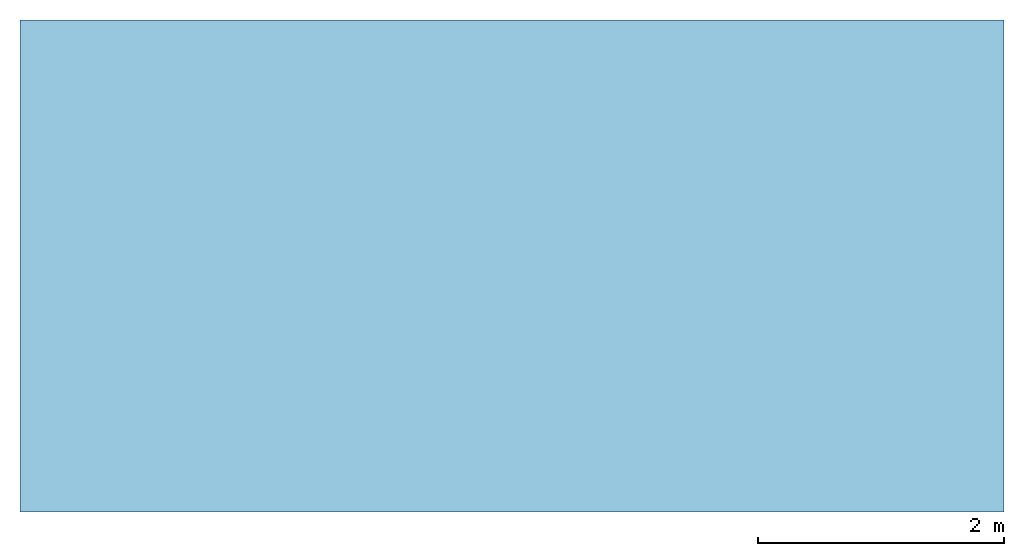
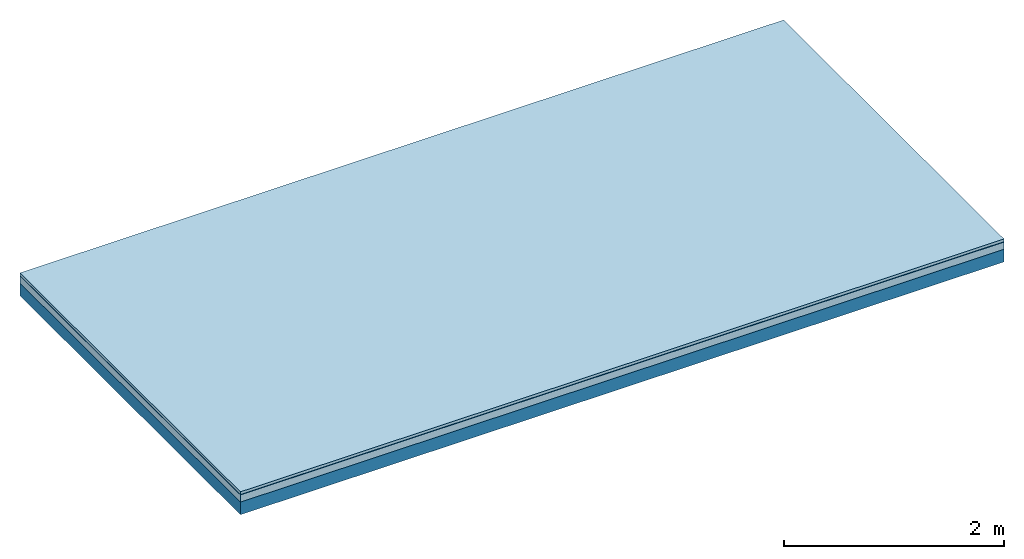
# One storey: 3 plates, 1 member, 1 element without a shape of its own.
"""IFC4 building model written with IfcOpenShell, lengths in metres."""

import ifcopenshell
import ifcopenshell.guid

model = None  # the IFC model being written
_history = None  # IfcOwnerHistory: only IFC2X3 demands one
_inside = {}  # id of a spatial element -> (the spatial element, [elements in it])
_under = {}  # id of a project, library or spatial element -> (it, [spatial elements below it])
_declared = {}  # id of a project -> (the project, [libraries it declares])
_typed = {}  # id of a type object -> (the type object, [elements of that type])
_made_of = {}  # id of a material, layer set ... -> (it, [elements and type objects made of it])


def new_model(schema):
    """Start an empty IFC model of exactly this schema.

    Asked for "IFC4X3", IfcOpenShell would pick the latest addendum, in which some entities
    have other attributes; the version numbers below select the first issue.
    IFC2X3 requires an IfcOwnerHistory on every rooted entity: one is made here for all.
    """
    global model, _history
    if schema == "IFC4X3":
        model = ifcopenshell.file(schema_version=(4, 3, 0, 0))
    else:
        model = ifcopenshell.file(schema=schema)
    _inside.clear()
    _under.clear()
    _declared.clear()
    _typed.clear()
    _made_of.clear()
    _history = None
    if model.schema == "IFC2X3":
        org = make("IfcOrganization", Name="unknown")
        user = make(
            "IfcPersonAndOrganization",
            ThePerson=make("IfcPerson", FamilyName="unknown"),
            TheOrganization=org,
        )
        app = make(
            "IfcApplication",
            ApplicationDeveloper=org,
            Version="unknown",
            ApplicationFullName="unknown",
            ApplicationIdentifier="unknown",
        )
        _history = make(
            "IfcOwnerHistory",
            OwningUser=user,
            OwningApplication=app,
            ChangeAction="ADDED",
            CreationDate=0,
        )
    return model


def make(cls, **values):
    """One entity of the class cls with the attributes given. An attribute that is None is left unset."""
    return model.create_entity(
        cls, **{name: value for name, value in values.items() if value is not None}
    )


def rooted(cls, **values):
    """An entity with a GlobalId (a new one), such as an element, a storey or a relation."""
    return make(cls, GlobalId=ifcopenshell.guid.new(), OwnerHistory=_history, **values)


def si_unit(unit_type, name, prefix=None):
    """IfcSIUnit, for example si_unit("LENGTHUNIT", "METRE", prefix="MILLI")."""
    return make("IfcSIUnit", UnitType=unit_type, Prefix=prefix, Name=name)


def derived_unit(unit_type, elements):
    """IfcDerivedUnit: a product of units, each with its exponent."""
    return make(
        "IfcDerivedUnit",
        Elements=[
            make("IfcDerivedUnitElement", Unit=unit, Exponent=power)
            for unit, power in elements
        ],
        UnitType=unit_type,
    )


def assignment(units):
    """IfcUnitAssignment: the units of a project."""
    return None if units is None else make("IfcUnitAssignment", Units=units)


def point(xyz):
    """IfcCartesianPoint."""
    return None if xyz is None else make("IfcCartesianPoint", Coordinates=xyz)


def direction(xyz):
    """IfcDirection."""
    return None if xyz is None else make("IfcDirection", DirectionRatios=xyz)


def frame(location, z_axis=None, x_axis=None):
    """IfcAxis2Placement3D, a coordinate frame: its origin and axes. An axis left out is left unset."""
    return make(
        "IfcAxis2Placement3D",
        Location=point(location),
        Axis=direction(z_axis),
        RefDirection=direction(x_axis),
    )


def frame_2d(location, x_axis=None):
    """IfcAxis2Placement2D, a coordinate frame in the plane: its origin and x axis."""
    return make(
        "IfcAxis2Placement2D", Location=point(location), RefDirection=direction(x_axis)
    )


def origin():
    """The frame at (0, 0, 0) with its axes left unset."""
    return frame((0.0, 0.0, 0.0))


def origin_with_axes():
    """The frame at (0, 0, 0) with the z axis (0, 0, 1) and the x axis (1, 0, 0) written out."""
    return frame((0.0, 0.0, 0.0), z_axis=(0.0, 0.0, 1.0), x_axis=(1.0, 0.0, 0.0))


def place(relative_to, where):
    """IfcLocalPlacement: puts the frame where relative to a parent placement (None: the world)."""
    return make(
        "IfcLocalPlacement", PlacementRelTo=relative_to, RelativePlacement=where
    )


def context(
    kind, dimensions, precision=None, world=None, true_north=None, identifier=None
):
    """IfcGeometricRepresentationContext, for example the 3D "Model" context."""
    return make(
        "IfcGeometricRepresentationContext",
        ContextIdentifier=identifier,
        ContextType=kind,
        CoordinateSpaceDimension=dimensions,
        Precision=precision,
        WorldCoordinateSystem=world,
        TrueNorth=true_north,
    )


def project(units=None, contexts=None):
    """IfcProject with its units and contexts."""
    return rooted(
        "IfcProject",
        Name="project",
        RepresentationContexts=contexts,
        UnitsInContext=assignment(units),
    )


def spatial(cls, under=None, at=None, **own):
    """A site, building, storey or space (cls), placed at a placement, below another one or the project."""
    s = rooted(cls, ObjectPlacement=at, **own)
    if under is not None:
        _under.setdefault(under.id(), (under, []))[1].append(s)
    return s


def profile(cls, at=None, kind="AREA", **sizes):
    """A parametric profile (cls). Its sizes go by their IFC names, for example OverallWidth=200.0."""
    return make(cls, ProfileType=kind, Position=at, **sizes)


def rectangle(**sizes):
    """IfcRectangleProfileDef."""
    return profile("IfcRectangleProfileDef", **sizes)


def extrude(swept, where, along, depth):
    """IfcExtrudedAreaSolid: the profile swept, set in the frame where, extruded along a direction by depth."""
    return make(
        "IfcExtrudedAreaSolid",
        SweptArea=swept,
        Position=where,
        ExtrudedDirection=direction(along),
        Depth=depth,
    )


def shape(context_of_items, identifier, shape_type, items):
    """IfcShapeRepresentation: the items that make up one representation, for example the "Body"."""
    return make(
        "IfcShapeRepresentation",
        ContextOfItems=context_of_items,
        RepresentationIdentifier=identifier,
        RepresentationType=shape_type,
        Items=items,
    )


def material(Name=None, Category=None):
    """IfcMaterial."""
    return make("IfcMaterial", Name=Name, Category=Category)


def layer(
    of_material, thickness, ventilated=None, Name=None, Category=None, Priority=None
):
    """IfcMaterialLayer: one layer of a wall or slab, of a material (None: an air gap)."""
    return make(
        "IfcMaterialLayer",
        Material=of_material,
        LayerThickness=thickness,
        IsVentilated=ventilated,
        Name=Name,
        Category=Category,
        Priority=Priority,
    )


def layer_set(layers, Name=None):
    """IfcMaterialLayerSet."""
    return make("IfcMaterialLayerSet", MaterialLayers=layers, LayerSetName=Name)


def made_of(thing, what):
    """Note that an element or type object is made of a material, layer set ...; save() writes the relation."""
    if what is not None:
        _made_of.setdefault(what.id(), (what, []))[1].append(thing)
    return thing


def type_object(cls, material=None, **own):
    """A type object (cls), such as IfcWallType, which elements share."""
    return made_of(rooted(cls, **own), material)


def element(
    cls,
    number,
    at=None,
    inside=None,
    cuts=None,
    type_object=None,
    material=None,
    context=None,
    identifier="Body",
    shape_type=None,
    held_by="IfcProductDefinitionShape",
    body=None,
    shapes=None,
    **own,
):
    """One element of the class cls, such as IfcWall. Its Tag is "e" and its number.

    at: its placement. inside: the storey or other place that contains it. cuts: it is an
    opening in that element (IfcRelVoidsElement). A single representation is given by context,
    identifier, shape_type and body (its items); several are given by shapes. held_by: the class
    of the entity that holds the representations. save() writes the other relations.
    """
    e = rooted(cls, Tag="e%d" % number, ObjectPlacement=at, **own)
    if body is not None:
        shapes = [shape(context, identifier, shape_type, body)]
    if shapes is not None:
        e.Representation = make(held_by, Representations=shapes)
    if inside is not None:
        _inside.setdefault(inside.id(), (inside, []))[1].append(e)
    if cuts is not None:
        rooted(
            "IfcRelVoidsElement", RelatingBuildingElement=cuts, RelatedOpeningElement=e
        )
    if type_object is not None:
        _typed.setdefault(type_object.id(), (type_object, []))[1].append(e)
    return made_of(e, material)


def aggregate(whole, parts):
    """IfcRelAggregates: a whole, such as a stair, and the parts it consists of."""
    return rooted("IfcRelAggregates", RelatingObject=whole, RelatedObjects=parts)


def save(model, path):
    """Write the relations noted so far, then the file.

    IfcRelAggregates (storeys below a building ...), IfcRelContainedInSpatialStructure (elements
    in a storey), IfcRelDefinesByType, IfcRelAssociatesMaterial and IfcRelDeclares: one each for
    every whole, place, type object, material and project.
    """
    for whole, parts in _under.values():
        aggregate(whole, parts)
    for where, things in _inside.values():
        rooted(
            "IfcRelContainedInSpatialStructure",
            RelatedElements=things,
            RelatingStructure=where,
        )
    for kind, things in _typed.values():
        rooted("IfcRelDefinesByType", RelatedObjects=things, RelatingType=kind)
    for what, things in _made_of.values():
        rooted("IfcRelAssociatesMaterial", RelatedObjects=things, RelatingMaterial=what)
    for by, libraries in _declared.values():
        rooted("IfcRelDeclares", RelatingContext=by, RelatedDefinitions=libraries)
    model.write(path)


model = new_model("IFC4")

# Units and contexts
plan_context = context("Plan", 3, precision=1e-05, world=origin(), true_north=direction((0.0, 1.0)))
model_context = context("Model", 3, precision=1e-05, world=origin(), true_north=direction((0.0, 1.0)))
ifc_project = project(units=[si_unit("LENGTHUNIT", "METRE"), derived_unit("SOUNDPRESSUREUNIT", [(si_unit("PRESSUREUNIT", "PASCAL", prefix="MICRO"), 0)]), si_unit("ENERGYUNIT", "JOULE", prefix="MEGA"), si_unit("MASSUNIT", "GRAM", prefix="KILO"), derived_unit("THERMALTRANSMITTANCEUNIT", [(si_unit("POWERUNIT", "WATT"), 1), (si_unit("AREAUNIT", "SQUARE_METRE"), -1), (si_unit("THERMODYNAMICTEMPERATUREUNIT", "KELVIN"), -1)]), derived_unit("AREADENSITYUNIT", [(si_unit("MASSUNIT", "GRAM", prefix="KILO"), 1), (si_unit("AREAUNIT", "SQUARE_METRE"), -1)]), derived_unit("USERDEFINED", [(si_unit("ENERGYUNIT", "JOULE", prefix="MEGA"), 1), (si_unit("AREAUNIT", "SQUARE_METRE"), -1)])], contexts=[plan_context, model_context])

# Site, building, storey
site = spatial("IfcSite", under=ifc_project)
building_placement = place(None, origin())
building = spatial("IfcBuilding", under=site, at=building_placement)
storey_placement = place(building_placement, origin())
storey = spatial("IfcBuildingStorey", under=building, at=storey_placement)

# Slab, member, plates
ifc_material_1 = material(Name="Phone Star TRI", Category="03.013")
ifc_layer_1 = layer(ifc_material_1, 0.03, Name="On-material")
ifc_material_2 = material(Name="Polyester-Platte")
ifc_layer_2 = layer(ifc_material_2, 0.004, Name="Impact sound insulation")
ifc_material_3 = material(Category="03.011")
ifc_layer_3 = layer(ifc_material_3, 0.08, Name="on Supporting structure")
ifc_material_4 = material(Name="no composite action")
ifc_layer_4 = layer(ifc_material_4, 0.0, Name="Bond")
ifc_layer_5 = layer(None, 0.14, Name="Supporting structure")
ifc_layer_set = layer_set([ifc_layer_1, ifc_layer_2, ifc_layer_3, ifc_layer_4, ifc_layer_5])
slab_type = type_object("IfcSlabType", Name="A2418", PredefinedType="NOTDEFINED", material=ifc_layer_set)
slab_placement = place(None, frame((0.0, 0.0, 0.0), z_axis=(0.0, 0.0, -1.0), x_axis=(1.0, 0.0, 0.0)))
slab = element("IfcSlab", 1, at=slab_placement, inside=storey, type_object=slab_type, material=ifc_layer_set, Name="Slab #1")
ifc_material_5 = material()
member_placement = place(slab_placement, origin())
member = element("IfcMember", 2, at=member_placement, material=ifc_material_5, Name="Supporting structure", context=plan_context, shape_type="SweptSolid", body=[
    extrude(rectangle(XDim=1.0, YDim=0.14, at=frame_2d((0.5, 0.07), x_axis=(1.0, 0.0))), frame((0.0, 4.0, 0.114), z_axis=(0.0, -1.0, 0.0), x_axis=(1.0, 0.0, 0.0)), (0.0, 0.0, 1.0), 4.0),
    extrude(rectangle(XDim=1.0, YDim=0.14, at=frame_2d((0.5, 0.07), x_axis=(1.0, 0.0))), frame((1.0, 4.0, 0.114), z_axis=(0.0, -1.0, 0.0), x_axis=(1.0, 0.0, 0.0)), (0.0, 0.0, 1.0), 4.0),
    extrude(rectangle(XDim=1.0, YDim=0.14, at=frame_2d((0.5, 0.07), x_axis=(1.0, 0.0))), frame((2.0, 4.0, 0.114), z_axis=(0.0, -1.0, 0.0), x_axis=(1.0, 0.0, 0.0)), (0.0, 0.0, 1.0), 4.0),
    extrude(rectangle(XDim=1.0, YDim=0.14, at=frame_2d((0.5, 0.07), x_axis=(1.0, 0.0))), frame((3.0, 4.0, 0.114), z_axis=(0.0, -1.0, 0.0), x_axis=(1.0, 0.0, 0.0)), (0.0, 0.0, 1.0), 4.0),
    extrude(rectangle(XDim=1.0, YDim=0.14, at=frame_2d((0.5, 0.07), x_axis=(1.0, 0.0))), frame((4.0, 4.0, 0.114), z_axis=(0.0, -1.0, 0.0), x_axis=(1.0, 0.0, 0.0)), (0.0, 0.0, 1.0), 4.0),
    extrude(rectangle(XDim=1.0, YDim=0.14, at=frame_2d((0.5, 0.07), x_axis=(1.0, 0.0))), frame((5.0, 4.0, 0.114), z_axis=(0.0, -1.0, 0.0), x_axis=(1.0, 0.0, 0.0)), (0.0, 0.0, 1.0), 4.0),
    extrude(rectangle(XDim=1.0, YDim=0.14, at=frame_2d((0.5, 0.07), x_axis=(1.0, 0.0))), frame((6.0, 4.0, 0.114), z_axis=(0.0, -1.0, 0.0), x_axis=(1.0, 0.0, 0.0)), (0.0, 0.0, 1.0), 4.0),
    extrude(rectangle(XDim=1.0, YDim=0.14, at=frame_2d((0.5, 0.07), x_axis=(1.0, 0.0))), frame((7.0, 4.0, 0.114), z_axis=(0.0, -1.0, 0.0), x_axis=(1.0, 0.0, 0.0)), (0.0, 0.0, 1.0), 4.0),
])
plate_1_placement = place(slab_placement, origin())
plate_1 = element("IfcPlate", 3, at=plate_1_placement, material=ifc_material_1, Name="On-material", context=plan_context, shape_type="SweptSolid", body=[
    extrude(rectangle(XDim=8.0, YDim=4.0, at=frame_2d((4.0, 2.0), x_axis=(1.0, 0.0))), origin_with_axes(), (0.0, 0.0, 1.0), 0.03),
])
plate_2_placement = place(slab_placement, origin())
plate_2 = element("IfcPlate", 4, at=plate_2_placement, material=ifc_material_2, Name="Impact sound insulation", context=plan_context, shape_type="SweptSolid", body=[
    extrude(rectangle(XDim=8.0, YDim=4.0, at=frame_2d((4.0, 2.0), x_axis=(1.0, 0.0))), frame((0.0, 0.0, 0.03), z_axis=(0.0, 0.0, 1.0), x_axis=(1.0, 0.0, 0.0)), (0.0, 0.0, 1.0), 0.004),
])
plate_3_placement = place(slab_placement, origin())
plate_3 = element("IfcPlate", 5, at=plate_3_placement, material=ifc_material_3, Name="on Supporting structure", context=plan_context, shape_type="SweptSolid", body=[
    extrude(rectangle(XDim=8.0, YDim=4.0, at=frame_2d((4.0, 2.0), x_axis=(1.0, 0.0))), frame((0.0, 0.0, 0.034), z_axis=(0.0, 0.0, 1.0), x_axis=(1.0, 0.0, 0.0)), (0.0, 0.0, 1.0), 0.08),
])
aggregate(slab, [plate_1, plate_2, plate_3, member])

save(model, "model.ifc")
